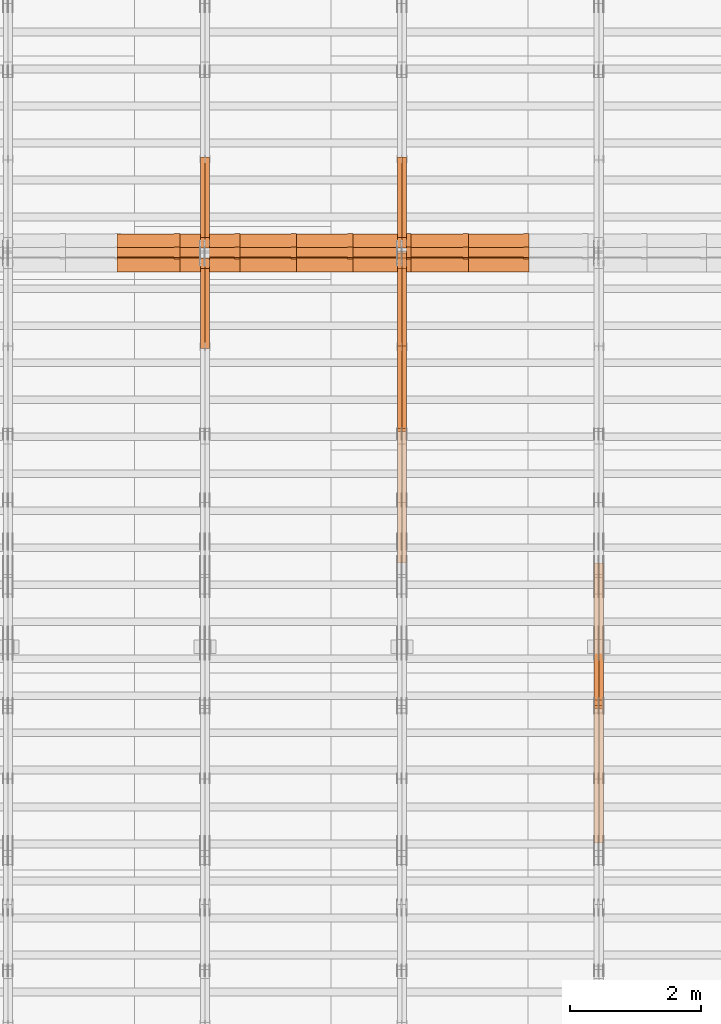
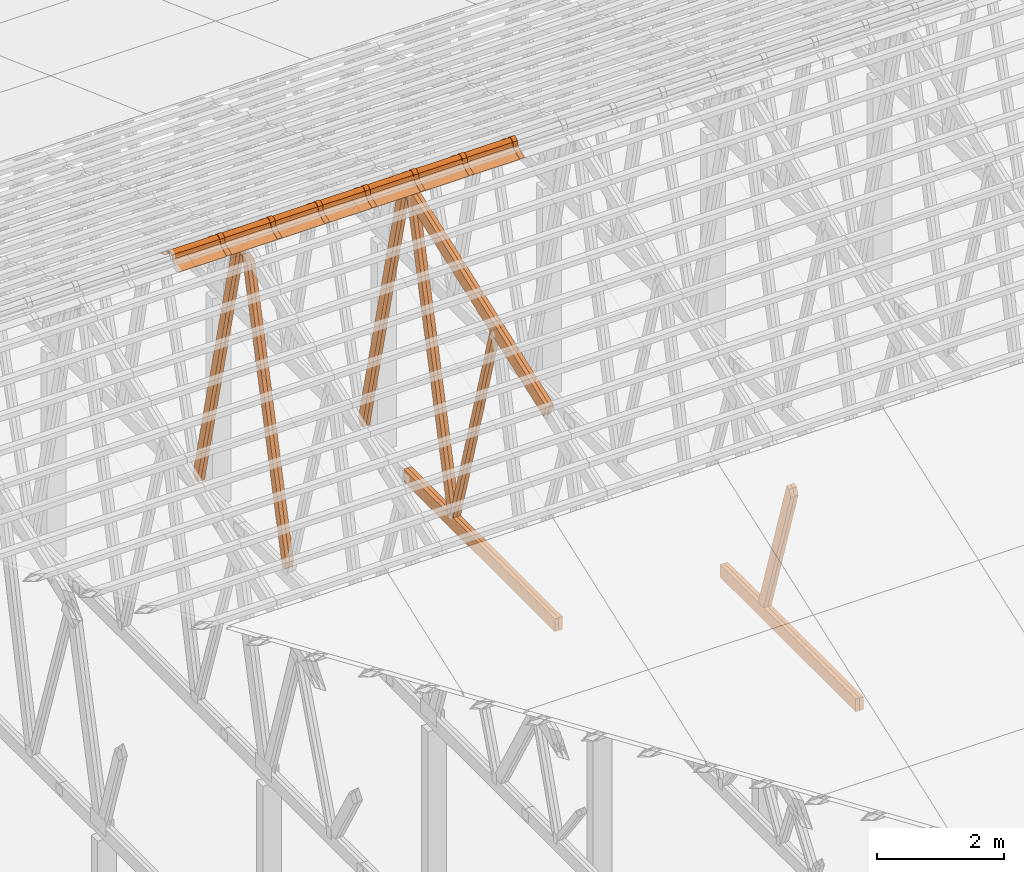
# One storey, part 27 of 189: 32 proxies.
"""IFC2X3 building model written with IfcOpenShell, lengths in millimetres."""

from ifc_helpers import new_model, entity, si_unit, converted_unit, derived_unit, direction, frame, frame_2d, origin, origin_2d_with_axis, place, context, subcontext, project, spatial, polyline, circle_curve, parameter, trimmed, segment, composite_curve, rectangle, outline, extrude, source, transform, mapped, material, type_object, type_shapes, element, save


model = new_model("IFC2X3")

# Units and contexts
model_context = context("Model", 3, precision=0.01, world=origin(), true_north=direction((6.12303176911189e-17, 1.0)))
body_context = subcontext(model_context, "Body", "Model", "MODEL_VIEW")
ifc_project = project(units=[si_unit("LENGTHUNIT", "METRE", prefix="MILLI"), si_unit("AREAUNIT", "SQUARE_METRE"), si_unit("VOLUMEUNIT", "CUBIC_METRE"), converted_unit("PLANEANGLEUNIT", "DEGREE", entity("IfcRatioMeasure", 0.0174532925199433), si_unit("PLANEANGLEUNIT", "RADIAN"), dimensions=[0, 0, 0, 0, 0, 0, 0]), si_unit("MASSUNIT", "GRAM", prefix="KILO"), derived_unit("MASSDENSITYUNIT", [(si_unit("MASSUNIT", "GRAM", prefix="KILO"), 1), (si_unit("LENGTHUNIT", "METRE"), -3)]), si_unit("TIMEUNIT", "SECOND"), si_unit("FREQUENCYUNIT", "HERTZ"), si_unit("THERMODYNAMICTEMPERATUREUNIT", "DEGREE_CELSIUS"), derived_unit("THERMALTRANSMITTANCEUNIT", [(si_unit("MASSUNIT", "GRAM", prefix="KILO"), 1), (si_unit("THERMODYNAMICTEMPERATUREUNIT", "KELVIN"), -1), (si_unit("TIMEUNIT", "SECOND"), -3)]), derived_unit("VOLUMETRICFLOWRATEUNIT", [(si_unit("LENGTHUNIT", "METRE"), 3), (si_unit("TIMEUNIT", "SECOND"), -1)]), si_unit("ELECTRICCURRENTUNIT", "AMPERE"), si_unit("ELECTRICVOLTAGEUNIT", "VOLT"), si_unit("POWERUNIT", "WATT"), si_unit("FORCEUNIT", "NEWTON"), si_unit("ILLUMINANCEUNIT", "LUX"), si_unit("LUMINOUSFLUXUNIT", "LUMEN"), si_unit("LUMINOUSINTENSITYUNIT", "CANDELA"), derived_unit("USERDEFINED", [(si_unit("MASSUNIT", "GRAM", prefix="KILO"), -1), (si_unit("LENGTHUNIT", "METRE"), -2), (si_unit("TIMEUNIT", "SECOND"), 3), (si_unit("LUMINOUSFLUXUNIT", "LUMEN"), 1)]), derived_unit("LINEARVELOCITYUNIT", [(si_unit("LENGTHUNIT", "METRE"), 1), (si_unit("TIMEUNIT", "SECOND"), -1)]), si_unit("PRESSUREUNIT", "PASCAL"), derived_unit("USERDEFINED", [(si_unit("LENGTHUNIT", "METRE"), -2), (si_unit("MASSUNIT", "GRAM", prefix="KILO"), 1), (si_unit("TIMEUNIT", "SECOND"), -2)])], contexts=[model_context])

# Site, building, storey
site_placement = place(None, origin())
site = spatial("IfcSite", under=ifc_project, at=site_placement, CompositionType="ELEMENT")
building_placement = place(site_placement, origin())
building = spatial("IfcBuilding", under=site, at=building_placement, CompositionType="ELEMENT")
storey_placement = place(building_placement, origin())
storey = spatial("IfcBuildingStorey", under=building, at=storey_placement, Name="Default", CompositionType="ELEMENT", Elevation=0.0)

# Proxies
ifc_material_1 = material(Name="IfcSurfaceStyle #130474")
building_element_proxy_type_1 = type_object("IfcBuildingElementProxyType", Name="T1-W4 130472", PredefinedType="NOTDEFINED", material=ifc_material_1)
shared_shape_1 = source(origin(), body_context, "Body", "SweptSolid", [
    extrude(outline(polyline([(-1688.09292256655, -85.0003489723785), (1071.44998120742, -85.0003489723785), (1178.19407811536, -0.00016040063201781), (1181.35435681367, 85.0004291726946), (-1742.9054935699, 85.0004291726946), (-1688.09292256655, -85.0003489723785)])), frame((1181.35446122976, 85.0007670757732, 0.0), z_axis=(0.0, 0.0, 1.0), x_axis=(-1.0, 0.0, 0.0)), (0.0, 0.0, 1.0), 69.9999999999998),
])
type_shapes(building_element_proxy_type_1, [shared_shape_1])
proxy_1_placement = place(building_placement, frame((24300.0, 7937.17021143291, 3028.170124945), z_axis=(-1.0, 0.0, 0.0), x_axis=(0.0, 0.306868406216492, -0.951751953644514)))
element("IfcBuildingElementProxy", 1, at=proxy_1_placement, inside=storey, type_object=building_element_proxy_type_1, material=ifc_material_1, Name="T1-W4", context=body_context, shape_type="MappedRepresentation", body=[
    mapped(shared_shape_1, transform((0.0, 0.0, 0.0), scale=1.0)),
])
ifc_material_2 = material(Name="IfcSurfaceStyle #130408")
building_element_proxy_type_2 = type_object("IfcBuildingElementProxyType", Name="T1-W4 130406", PredefinedType="NOTDEFINED", material=ifc_material_2)
shared_shape_2 = source(origin(), body_context, "Body", "SweptSolid", [
    extrude(outline(polyline([(-1688.09292256655, -85.0003489723785), (1071.44998120742, -85.0003489723785), (1178.19407811536, -0.00016040063201781), (1181.35435681367, 85.0004291726946), (-1742.9054935699, 85.0004291726946), (-1688.09292256655, -85.0003489723785)])), frame((1181.35446122976, 85.0007670757732, 0.0), z_axis=(0.0, 0.0, 1.0), x_axis=(-1.0, 0.0, 0.0)), (0.0, 0.0, 1.0), 69.9999999999998),
])
type_shapes(building_element_proxy_type_2, [shared_shape_2])
proxy_2_placement = place(building_placement, frame((24230.0, 7937.17021143291, 3028.170124945), z_axis=(-1.0, 0.0, 0.0), x_axis=(0.0, 0.306868406216492, -0.951751953644514)))
element("IfcBuildingElementProxy", 2, at=proxy_2_placement, inside=storey, type_object=building_element_proxy_type_2, material=ifc_material_2, Name="T1-W4", context=body_context, shape_type="MappedRepresentation", body=[
    mapped(shared_shape_2, transform((0.0, 0.0, 0.0), scale=1.0)),
])
ifc_material_3 = material(Name="IfcSurfaceStyle #127396")
building_element_proxy_type_3 = type_object("IfcBuildingElementProxyType", Name="T1-B6 127394", PredefinedType="NOTDEFINED", material=ifc_material_3)
shared_shape_3 = source(origin(), body_context, "Body", "SweptSolid", [
    extrude(rectangle(XDim=4266.763671875, YDim=245.000000000001, at=origin_2d_with_axis()), frame((2133.3818359375, 122.500000000001, 0.0), z_axis=(0.0, 0.0, 1.0), x_axis=(-1.0, 0.0, 0.0)), (0.0, 0.0, 1.0), 69.9999999999997),
])
type_shapes(building_element_proxy_type_3, [shared_shape_3])
proxy_3_placement = place(building_placement, frame((24300.0, 5762.466796875, 245.0), z_axis=(-1.0, 0.0, 0.0), x_axis=(0.0, 1.0, 0.0)))
element("IfcBuildingElementProxy", 3, at=proxy_3_placement, inside=storey, type_object=building_element_proxy_type_3, material=ifc_material_3, Name="T1-B6", context=body_context, shape_type="MappedRepresentation", body=[
    mapped(shared_shape_3, transform((0.0, 0.0, 0.0), scale=1.0)),
])
ifc_material_4 = material(Name="IfcSurfaceStyle #127339")
building_element_proxy_type_4 = type_object("IfcBuildingElementProxyType", Name="T1-B6 127337", PredefinedType="NOTDEFINED", material=ifc_material_4)
shared_shape_4 = source(origin(), body_context, "Body", "SweptSolid", [
    extrude(rectangle(XDim=4266.763671875, YDim=245.000000000001, at=origin_2d_with_axis()), frame((2133.3818359375, 122.500000000001, 0.0), z_axis=(0.0, 0.0, 1.0), x_axis=(-1.0, 0.0, 0.0)), (0.0, 0.0, 1.0), 69.9999999999997),
])
type_shapes(building_element_proxy_type_4, [shared_shape_4])
proxy_4_placement = place(building_placement, frame((24230.0, 5762.466796875, 245.0), z_axis=(-1.0, 0.0, 0.0), x_axis=(0.0, 1.0, 0.0)))
element("IfcBuildingElementProxy", 4, at=proxy_4_placement, inside=storey, type_object=building_element_proxy_type_4, material=ifc_material_4, Name="T1-B6", context=body_context, shape_type="MappedRepresentation", body=[
    mapped(shared_shape_4, transform((0.0, 0.0, 0.0), scale=1.0)),
])
ifc_material_5 = material(Name="IfcSurfaceStyle #116004")
building_element_proxy_type_5 = type_object("IfcBuildingElementProxyType", Name="T1-W5 116002", PredefinedType="NOTDEFINED", material=ifc_material_5)
shared_shape_5 = source(origin(), body_context, "Body", "SweptSolid", [
    extrude(outline(polyline([(-3233.61216530572, -72.4999091305202), (2153.79187521892, -72.4999091305202), (2171.36968478227, -7.18521572819375e-05), (2045.62106208646, 72.4999450565989), (-3137.17045678193, 72.4999450565989), (-3233.61216530572, -72.4999091305202)])), frame((2171.36968478227, 72.500192121173, 0.0), z_axis=(0.0, 0.0, 1.0), x_axis=(-1.0, 0.0, 0.0)), (0.0, 0.0, 1.0), 69.9999999999997),
])
type_shapes(building_element_proxy_type_5, [shared_shape_5])
proxy_5_placement = place(building_placement, frame((21300.0, 13261.0146935344, 262.082919891325), z_axis=(-1.0, 0.0, 0.0), x_axis=(0.0, 0.235625623344066, 0.97184389982328)))
element("IfcBuildingElementProxy", 5, at=proxy_5_placement, inside=storey, type_object=building_element_proxy_type_5, material=ifc_material_5, Name="T1-W5", context=body_context, shape_type="MappedRepresentation", body=[
    mapped(shared_shape_5, transform((0.0, 0.0, 0.0), scale=1.0)),
])
ifc_material_6 = material(Name="IfcSurfaceStyle #115938")
building_element_proxy_type_6 = type_object("IfcBuildingElementProxyType", Name="T1-W5 115936", PredefinedType="NOTDEFINED", material=ifc_material_6)
shared_shape_6 = source(origin(), body_context, "Body", "SweptSolid", [
    extrude(outline(polyline([(-3233.61216530572, -72.4999091305202), (2153.79187521892, -72.4999091305202), (2171.36968478227, -7.18521572819375e-05), (2045.62106208646, 72.4999450565989), (-3137.17045678193, 72.4999450565989), (-3233.61216530572, -72.4999091305202)])), frame((2171.36968478227, 72.500192121173, 0.0), z_axis=(0.0, 0.0, 1.0), x_axis=(-1.0, 0.0, 0.0)), (0.0, 0.0, 1.0), 69.9999999999997),
])
type_shapes(building_element_proxy_type_6, [shared_shape_6])
proxy_6_placement = place(building_placement, frame((21230.0, 13261.0146935344, 262.082919891325), z_axis=(-1.0, 0.0, 0.0), x_axis=(0.0, 0.235625623344066, 0.97184389982328)))
element("IfcBuildingElementProxy", 6, at=proxy_6_placement, inside=storey, type_object=building_element_proxy_type_6, material=ifc_material_6, Name="T1-W5", context=body_context, shape_type="MappedRepresentation", body=[
    mapped(shared_shape_6, transform((0.0, 0.0, 0.0), scale=1.0)),
])
ifc_material_7 = material(Name="IfcSurfaceStyle #115872")
building_element_proxy_type_7 = type_object("IfcBuildingElementProxyType", Name="T1-W5 115870", PredefinedType="NOTDEFINED", material=ifc_material_7)
shared_shape_7 = source(origin(), body_context, "Body", "SweptSolid", [
    extrude(outline(polyline([(-3137.17045678193, -72.5002081306407), (2045.62106208646, -72.5002081306408), (2171.36968478227, 5.58426931168476e-05), (2153.79187521892, 72.5001802092942), (-3233.61216530572, 72.5001802092942), (-3137.17045678193, -72.5002081306407)])), frame((2171.36968478227, 72.5001802092942, 0.0), z_axis=(0.0, 0.0, 1.0), x_axis=(-1.0, 0.0, 0.0)), (0.0, 0.0, 1.0), 69.9999999999997),
])
type_shapes(building_element_proxy_type_7, [shared_shape_7])
proxy_7_placement = place(building_placement, frame((21300.0, 16098.0675635854, 227.917113003597), z_axis=(-1.0, 0.0, 0.0), x_axis=(0.0, -0.235625623344066, 0.971843899823279)))
element("IfcBuildingElementProxy", 7, at=proxy_7_placement, inside=storey, type_object=building_element_proxy_type_7, material=ifc_material_7, Name="T1-W5", context=body_context, shape_type="MappedRepresentation", body=[
    mapped(shared_shape_7, transform((0.0, 0.0, 0.0), scale=1.0)),
])
ifc_material_8 = material(Name="IfcSurfaceStyle #115806")
building_element_proxy_type_8 = type_object("IfcBuildingElementProxyType", Name="T1-W5 115804", PredefinedType="NOTDEFINED", material=ifc_material_8)
shared_shape_8 = source(origin(), body_context, "Body", "SweptSolid", [
    extrude(outline(polyline([(-3137.17045678193, -72.5002081306407), (2045.62106208646, -72.5002081306408), (2171.36968478227, 5.58426931168476e-05), (2153.79187521892, 72.5001802092942), (-3233.61216530572, 72.5001802092942), (-3137.17045678193, -72.5002081306407)])), frame((2171.36968478227, 72.5001802092942, 0.0), z_axis=(0.0, 0.0, 1.0), x_axis=(-1.0, 0.0, 0.0)), (0.0, 0.0, 1.0), 69.9999999999997),
])
type_shapes(building_element_proxy_type_8, [shared_shape_8])
proxy_8_placement = place(building_placement, frame((21230.0, 16098.0675635854, 227.917113003597), z_axis=(-1.0, 0.0, 0.0), x_axis=(0.0, -0.235625623344066, 0.971843899823279)))
element("IfcBuildingElementProxy", 8, at=proxy_8_placement, inside=storey, type_object=building_element_proxy_type_8, material=ifc_material_8, Name="T1-W5", context=body_context, shape_type="MappedRepresentation", body=[
    mapped(shared_shape_8, transform((0.0, 0.0, 0.0), scale=1.0)),
])
ifc_material_9 = material(Name="IfcSurfaceStyle #115740")
building_element_proxy_type_9 = type_object("IfcBuildingElementProxyType", Name="T1-W6 115738", PredefinedType="NOTDEFINED", material=ifc_material_9)
shared_shape_9 = source(origin(), body_context, "Body", "SweptSolid", [
    extrude(outline(polyline([(-2640.84340836012, -47.4996765865792), (1711.12245024294, -47.4996765865792), (1797.68490303083, -9.57690019346202e-05), (1800.72595169379, 47.4997244710801), (-2668.68989660745, 47.4997244710801), (-2640.84340836012, -47.4996765865792)])), frame((1800.72595169379, 47.5003009358159, 0.0), z_axis=(0.0, 0.0, 1.0), x_axis=(-1.0, 0.0, 0.0)), (0.0, 0.0, 1.0), 69.9999999999997),
])
type_shapes(building_element_proxy_type_9, [shared_shape_9])
proxy_9_placement = place(building_placement, frame((21300.0, 12074.2896156894, 4533.9586582452), z_axis=(-1.0, 0.0, 0.0), x_axis=(0.0, 0.28128598310461, -0.959623986626467)))
element("IfcBuildingElementProxy", 9, at=proxy_9_placement, inside=storey, type_object=building_element_proxy_type_9, material=ifc_material_9, Name="T1-W6", context=body_context, shape_type="MappedRepresentation", body=[
    mapped(shared_shape_9, transform((0.0, 0.0, 0.0), scale=1.0)),
])
ifc_material_10 = material(Name="IfcSurfaceStyle #115674")
building_element_proxy_type_10 = type_object("IfcBuildingElementProxyType", Name="T1-W6 115672", PredefinedType="NOTDEFINED", material=ifc_material_10)
shared_shape_10 = source(origin(), body_context, "Body", "SweptSolid", [
    extrude(outline(polyline([(-2640.84340836012, -47.4996765865792), (1711.12245024294, -47.4996765865792), (1797.68490303083, -9.57690019346202e-05), (1800.72595169379, 47.4997244710801), (-2668.68989660745, 47.4997244710801), (-2640.84340836012, -47.4996765865792)])), frame((1800.72595169379, 47.5003009358159, 0.0), z_axis=(0.0, 0.0, 1.0), x_axis=(-1.0, 0.0, 0.0)), (0.0, 0.0, 1.0), 69.9999999999997),
])
type_shapes(building_element_proxy_type_10, [shared_shape_10])
proxy_10_placement = place(building_placement, frame((21230.0, 12074.2896156894, 4533.9586582452), z_axis=(-1.0, 0.0, 0.0), x_axis=(0.0, 0.28128598310461, -0.959623986626467)))
element("IfcBuildingElementProxy", 10, at=proxy_10_placement, inside=storey, type_object=building_element_proxy_type_10, material=ifc_material_10, Name="T1-W6", context=body_context, shape_type="MappedRepresentation", body=[
    mapped(shared_shape_10, transform((0.0, 0.0, 0.0), scale=1.0)),
])
ifc_material_11 = material(Name="IfcSurfaceStyle #111720")
building_element_proxy_type_11 = type_object("IfcBuildingElementProxyType", Name="T1-B3 111718", PredefinedType="NOTDEFINED", material=ifc_material_11)
shared_shape_11 = source(origin(), body_context, "Body", "SweptSolid", [
    extrude(rectangle(XDim=4751.0283203125, YDim=245.000000000001, at=origin_2d_with_axis()), frame((2375.51416015625, 122.5, 0.0), z_axis=(0.0, 0.0, 1.0), x_axis=(-1.0, 0.0, 0.0)), (0.0, 0.0, 1.0), 69.9999999999997),
])
type_shapes(building_element_proxy_type_11, [shared_shape_11])
proxy_11_placement = place(building_placement, frame((21300.0, 10029.23046875, 245.0), z_axis=(-1.0, 0.0, 0.0), x_axis=(0.0, 1.0, 0.0)))
element("IfcBuildingElementProxy", 11, at=proxy_11_placement, inside=storey, type_object=building_element_proxy_type_11, material=ifc_material_11, Name="T1-B3", context=body_context, shape_type="MappedRepresentation", body=[
    mapped(shared_shape_11, transform((0.0, 0.0, 0.0), scale=1.0)),
])
ifc_material_12 = material(Name="IfcSurfaceStyle #111663")
building_element_proxy_type_12 = type_object("IfcBuildingElementProxyType", Name="T1-B3 111661", PredefinedType="NOTDEFINED", material=ifc_material_12)
shared_shape_12 = source(origin(), body_context, "Body", "SweptSolid", [
    extrude(rectangle(XDim=4751.0283203125, YDim=245.000000000001, at=origin_2d_with_axis()), frame((2375.51416015625, 122.5, 0.0), z_axis=(0.0, 0.0, 1.0), x_axis=(-1.0, 0.0, 0.0)), (0.0, 0.0, 1.0), 69.9999999999997),
])
type_shapes(building_element_proxy_type_12, [shared_shape_12])
proxy_12_placement = place(building_placement, frame((21230.0, 10029.23046875, 245.0), z_axis=(-1.0, 0.0, 0.0), x_axis=(0.0, 1.0, 0.0)))
element("IfcBuildingElementProxy", 12, at=proxy_12_placement, inside=storey, type_object=building_element_proxy_type_12, material=ifc_material_12, Name="T1-B3", context=body_context, shape_type="MappedRepresentation", body=[
    mapped(shared_shape_12, transform((0.0, 0.0, 0.0), scale=1.0)),
])
ifc_material_13 = material(Name="IfcSurfaceStyle #111132")
building_element_proxy_type_13 = type_object("IfcBuildingElementProxyType", Name="T1-T3 111130", PredefinedType="NOTDEFINED", material=ifc_material_13)
shared_shape_13 = source(origin(), body_context, "Body", "SweptSolid", [
    extrude(outline(polyline([(-2341.64890001385, -122.499972785692), (2386.23525922045, -122.499972785692), (2297.06252495753, 122.499972785692), (-2341.64888416412, 122.499972785692), (-2341.64890001385, -122.499972785692)])), frame((2386.23525922045, 122.499973888764, 0.0), z_axis=(0.0, 0.0, 1.0), x_axis=(-1.0, 0.0, 0.0)), (0.0, 0.0, 1.0), 69.9999999999997),
])
type_shapes(building_element_proxy_type_13, [shared_shape_13])
proxy_13_placement = place(building_placement, frame((21300.0, 14833.7949607394, 5538.33627266055), z_axis=(-1.0, 0.0, 0.0), x_axis=(0.0, -0.939692620785908, -0.342020143325669)))
element("IfcBuildingElementProxy", 13, at=proxy_13_placement, inside=storey, type_object=building_element_proxy_type_13, material=ifc_material_13, Name="T1-T3", context=body_context, shape_type="MappedRepresentation", body=[
    mapped(shared_shape_13, transform((0.0, 0.0, 0.0), scale=1.0)),
])
ifc_material_14 = material(Name="IfcSurfaceStyle #111075")
building_element_proxy_type_14 = type_object("IfcBuildingElementProxyType", Name="T1-T3 111073", PredefinedType="NOTDEFINED", material=ifc_material_14)
shared_shape_14 = source(origin(), body_context, "Body", "SweptSolid", [
    extrude(outline(polyline([(-2341.64890001385, -122.499972785692), (2386.23525922045, -122.499972785692), (2297.06252495753, 122.499972785692), (-2341.64888416412, 122.499972785692), (-2341.64890001385, -122.499972785692)])), frame((2386.23525922045, 122.499973888764, 0.0), z_axis=(0.0, 0.0, 1.0), x_axis=(-1.0, 0.0, 0.0)), (0.0, 0.0, 1.0), 69.9999999999997),
])
type_shapes(building_element_proxy_type_14, [shared_shape_14])
proxy_14_placement = place(building_placement, frame((21230.0, 14833.7949607394, 5538.33627266055), z_axis=(-1.0, 0.0, 0.0), x_axis=(0.0, -0.939692620785908, -0.342020143325669)))
element("IfcBuildingElementProxy", 14, at=proxy_14_placement, inside=storey, type_object=building_element_proxy_type_14, material=ifc_material_14, Name="T1-T3", context=body_context, shape_type="MappedRepresentation", body=[
    mapped(shared_shape_14, transform((0.0, 0.0, 0.0), scale=1.0)),
])
ifc_material_15 = material(Name="IfcSurfaceStyle #100214")
building_element_proxy_type_15 = type_object("IfcBuildingElementProxyType", Name="T1-W5 100212", PredefinedType="NOTDEFINED", material=ifc_material_15)
shared_shape_15 = source(origin(), body_context, "Body", "SweptSolid", [
    extrude(outline(polyline([(-3233.61216530572, -72.4999091305202), (2153.79187521892, -72.4999091305202), (2171.36968478227, -7.18521572819375e-05), (2045.62106208646, 72.4999450565989), (-3137.17045678193, 72.4999450565989), (-3233.61216530572, -72.4999091305202)])), frame((2171.36968478227, 72.500192121173, 0.0), z_axis=(0.0, 0.0, 1.0), x_axis=(-1.0, 0.0, 0.0)), (0.0, 0.0, 1.0), 69.9999999999997),
])
type_shapes(building_element_proxy_type_15, [shared_shape_15])
proxy_15_placement = place(building_placement, frame((18300.0, 13261.0146935344, 262.082919891325), z_axis=(-1.0, 0.0, 0.0), x_axis=(0.0, 0.235625623344066, 0.97184389982328)))
element("IfcBuildingElementProxy", 15, at=proxy_15_placement, inside=storey, type_object=building_element_proxy_type_15, material=ifc_material_15, Name="T1-W5", context=body_context, shape_type="MappedRepresentation", body=[
    mapped(shared_shape_15, transform((0.0, 0.0, 0.0), scale=1.0)),
])
ifc_material_16 = material(Name="IfcSurfaceStyle #100148")
building_element_proxy_type_16 = type_object("IfcBuildingElementProxyType", Name="T1-W5 100146", PredefinedType="NOTDEFINED", material=ifc_material_16)
shared_shape_16 = source(origin(), body_context, "Body", "SweptSolid", [
    extrude(outline(polyline([(-3233.61216530572, -72.4999091305202), (2153.79187521892, -72.4999091305202), (2171.36968478227, -7.18521572819375e-05), (2045.62106208646, 72.4999450565989), (-3137.17045678193, 72.4999450565989), (-3233.61216530572, -72.4999091305202)])), frame((2171.36968478227, 72.500192121173, 0.0), z_axis=(0.0, 0.0, 1.0), x_axis=(-1.0, 0.0, 0.0)), (0.0, 0.0, 1.0), 69.9999999999997),
])
type_shapes(building_element_proxy_type_16, [shared_shape_16])
proxy_16_placement = place(building_placement, frame((18230.0, 13261.0146935344, 262.082919891325), z_axis=(-1.0, 0.0, 0.0), x_axis=(0.0, 0.235625623344066, 0.97184389982328)))
element("IfcBuildingElementProxy", 16, at=proxy_16_placement, inside=storey, type_object=building_element_proxy_type_16, material=ifc_material_16, Name="T1-W5", context=body_context, shape_type="MappedRepresentation", body=[
    mapped(shared_shape_16, transform((0.0, 0.0, 0.0), scale=1.0)),
])
ifc_material_17 = material(Name="IfcSurfaceStyle #100082")
building_element_proxy_type_17 = type_object("IfcBuildingElementProxyType", Name="T1-W5 100080", PredefinedType="NOTDEFINED", material=ifc_material_17)
shared_shape_17 = source(origin(), body_context, "Body", "SweptSolid", [
    extrude(outline(polyline([(-3137.17045678193, -72.5002081306407), (2045.62106208646, -72.5002081306408), (2171.36968478227, 5.58426931168476e-05), (2153.79187521892, 72.5001802092942), (-3233.61216530572, 72.5001802092942), (-3137.17045678193, -72.5002081306407)])), frame((2171.36968478227, 72.5001802092942, 0.0), z_axis=(0.0, 0.0, 1.0), x_axis=(-1.0, 0.0, 0.0)), (0.0, 0.0, 1.0), 69.9999999999997),
])
type_shapes(building_element_proxy_type_17, [shared_shape_17])
proxy_17_placement = place(building_placement, frame((18300.0, 16098.0675635854, 227.917113003597), z_axis=(-1.0, 0.0, 0.0), x_axis=(0.0, -0.235625623344066, 0.971843899823279)))
element("IfcBuildingElementProxy", 17, at=proxy_17_placement, inside=storey, type_object=building_element_proxy_type_17, material=ifc_material_17, Name="T1-W5", context=body_context, shape_type="MappedRepresentation", body=[
    mapped(shared_shape_17, transform((0.0, 0.0, 0.0), scale=1.0)),
])
ifc_material_18 = material(Name="IfcSurfaceStyle #100016")
building_element_proxy_type_18 = type_object("IfcBuildingElementProxyType", Name="T1-W5 100014", PredefinedType="NOTDEFINED", material=ifc_material_18)
shared_shape_18 = source(origin(), body_context, "Body", "SweptSolid", [
    extrude(outline(polyline([(-3137.17045678193, -72.5002081306407), (2045.62106208646, -72.5002081306408), (2171.36968478227, 5.58426931168476e-05), (2153.79187521892, 72.5001802092942), (-3233.61216530572, 72.5001802092942), (-3137.17045678193, -72.5002081306407)])), frame((2171.36968478227, 72.5001802092942, 0.0), z_axis=(0.0, 0.0, 1.0), x_axis=(-1.0, 0.0, 0.0)), (0.0, 0.0, 1.0), 69.9999999999997),
])
type_shapes(building_element_proxy_type_18, [shared_shape_18])
proxy_18_placement = place(building_placement, frame((18230.0, 16098.0675635854, 227.917113003597), z_axis=(-1.0, 0.0, 0.0), x_axis=(0.0, -0.235625623344066, 0.971843899823279)))
element("IfcBuildingElementProxy", 18, at=proxy_18_placement, inside=storey, type_object=building_element_proxy_type_18, material=ifc_material_18, Name="T1-W5", context=body_context, shape_type="MappedRepresentation", body=[
    mapped(shared_shape_18, transform((0.0, 0.0, 0.0), scale=1.0)),
])
ifc_material_19 = material()
building_element_proxy_type_19 = type_object("IfcBuildingElementProxyType", Name="P75", PredefinedType="NOTDEFINED", material=ifc_material_19)
shared_shape_19 = source(origin(), body_context, "Body", "SweptSolid", [
    extrude(outline(composite_curve([segment(polyline([(-69.4623915065845, -4.60763114971976), (47.4521071665907, -4.60763114971981)]), True, "CONTINUOUS"), segment(trimmed(circle_curve(frame_2d((119.940978060963, 14.6372018310859), x_axis=(-0.966518278591622, -0.256597773077395)), 75.0), [parameter(6.61555373744412e-13)], [parameter(180.0)], True, "PARAMETER"), True, "CONTINUOUS"), segment(polyline([(192.429848955335, 33.882034811891), (182.764666169419, 31.3160570811166)]), True, "CONTINUOUS"), segment(trimmed(circle_curve(frame_2d((119.940978060963, 14.6372018310859), x_axis=(-0.966518278591622, -0.256597773077395)), 65.0), [parameter(1.06866637297174e-12)], [parameter(180.0)], True, "PARAMETER"), False, "CONTINUOUS"), segment(polyline([(57.1172899525073, -2.04165341894578), (47.4521071665911, 5.39236885028051)]), True, "CONTINUOUS"), segment(polyline([(47.4521071665911, 5.39236885028052), (-70.7672243976422, 5.39236885028094)]), True, "CONTINUOUS"), segment(polyline([(-70.7672243976422, 5.39236885028094), (-194.776190618495, -27.5303655446341)]), True, "CONTINUOUS"), segment(polyline([(-194.776190618495, -27.5303655446341), (-192.210212887721, -37.1955483305503)]), True, "CONTINUOUS"), segment(polyline([(-192.210212887721, -37.1955483305503), (-69.4623915065845, -4.60763114971974)]), True, "CONTINUOUS")], self_intersect=False)), frame((0.0, 106.775760402721, -56.5599052870917), z_axis=(1.0, 0.0, 0.0), x_axis=(0.0, -0.820468487122275, 0.571691754041709)), (0.0, 0.0, 1.0), 867.000000000001),
    extrude(outline(composite_curve([segment(polyline([(62.2906866429439, -18.428943356533), (189.290686642944, -18.428943356533)]), True, "CONTINUOUS"), segment(polyline([(189.290686642944, -18.428943356533), (189.290686642944, -8.42894335653292)]), True, "CONTINUOUS"), segment(polyline([(189.290686642944, -8.42894335653292), (62.2906866429439, -8.42894335653294)]), True, "CONTINUOUS"), segment(polyline([(62.2906866429439, -8.42894335653294), (-41.0348065006093, 19.0026034957362)]), True, "CONTINUOUS"), segment(trimmed(circle_curve(frame_2d((-125.709313357056, 11.5710566434651), x_axis=(1.0, 0.0)), 85.0), [parameter(5.01577186738723)], [parameter(180.0)], True, "PARAMETER"), True, "CONTINUOUS"), segment(polyline([(-210.709313357056, 11.5710566434656), (-200.709313357056, 11.5710566434656)]), True, "CONTINUOUS"), segment(trimmed(circle_curve(frame_2d((-125.709313357056, 11.5710566434651), x_axis=(1.0, 0.0)), 75.0), [parameter(3.05333249420498e-13)], [parameter(180.0)], True, "PARAMETER"), False, "CONTINUOUS"), segment(polyline([(-50.7093133570542, 11.5710566434655), (62.290686642944, -18.4289433565322)]), True, "CONTINUOUS")], self_intersect=False)), frame((867.0, 114.170579674061, -53.8683539143053), z_axis=(1.0, 0.0, 0.0), x_axis=(0.0, 0.939692620785914, -0.342020143325653)), (0.0, 0.0, 1.0), 86.9999999999998),
])
type_shapes(building_element_proxy_type_19, [shared_shape_19])
for number, where, name in (
    (19, (22212.9353253273, 14755.0000438631, 5865.69618295448), "P75, generic model20:P75"),
    (20, (21292.9353253273, 14755.0000438631, 5865.69618295448), "P75, generic model20:P75"),
    (21, (20412.9353253273, 14755.0000438631, 5865.69618295448), "P75, generic model20:P75"),
    (22, (19532.9353253273, 14755.0000438631, 5865.69618295448), "P75, generic model20:P75"),
    (23, (18672.9353253273, 14755.0000438631, 5865.69618295448), "P75, generic model20:P75"),
    (24, (17812.9353253273, 14755.0000438631, 5865.69618295448), "P75, generic model20:P75"),
    (25, (16892.9353253273, 14755.0000438631, 5865.69618295448), "P75, generic model20:P75"),
):
    element("IfcBuildingElementProxy", number, at=place(storey_placement, frame(where)), inside=storey, type_object=building_element_proxy_type_19, material=ifc_material_19, Name=name, ObjectType="P75, generic model20:P75", context=body_context, shape_type="MappedRepresentation", body=[
        mapped(shared_shape_19, transform((0.0, 0.0, 0.0), scale=1.0)),
    ])
building_element_proxy_type_20 = type_object("IfcBuildingElementProxyType", Name="P75", PredefinedType="NOTDEFINED", material=ifc_material_19)
shared_shape_20 = source(origin(), body_context, "Body", "SweptSolid", [
    extrude(outline(composite_curve([segment(polyline([(68.3189789579817, 13.3705352460084), (195.318978957982, 13.3705352460084)]), True, "CONTINUOUS"), segment(polyline([(195.318978957982, 13.3705352460084), (195.318978957982, 23.3705352460084)]), True, "CONTINUOUS"), segment(polyline([(195.318978957982, 23.3705352460084), (67.014146066922, 23.3705352460088)]), True, "CONTINUOUS"), segment(polyline([(67.014146066922, 23.3705352460088), (-47.2469987727929, -6.96428196807339)]), True, "CONTINUOUS"), segment(polyline([(-47.2469987727929, -6.96428196807339), (-54.6810210420187, -16.62946475399)]), True, "CONTINUOUS"), segment(trimmed(circle_curve(frame_2d((-119.681021042019, -16.6294647539896), x_axis=(1.0, 0.0)), 65.0), [parameter(180.0)], [parameter(359.999999999999)], True, "PARAMETER"), False, "CONTINUOUS"), segment(polyline([(-184.681021042019, -16.6294647539905), (-194.681021042019, -16.6294647539901)]), True, "CONTINUOUS"), segment(trimmed(circle_curve(frame_2d((-119.681021042019, -16.6294647539896), x_axis=(1.0, 0.0)), 75.0), [parameter(180.0)], [parameter(359.999999999999)], True, "PARAMETER"), True, "CONTINUOUS"), segment(polyline([(-44.6810210420183, -16.6294647539898), (68.3189789579816, 13.3705352460083)]), True, "CONTINUOUS")], self_intersect=False)), frame((0.0, -106.775760402721, -56.5599052870916), z_axis=(1.0, 0.0, 0.0), x_axis=(0.0, -0.939692620785914, -0.342020143325654)), (0.0, 0.0, 1.0), 867.000000000001),
    extrude(outline(composite_curve([segment(polyline([(-64.9339130518847, 1.82825913317695), (-187.681734433021, -30.7596580476538)]), True, "CONTINUOUS"), segment(polyline([(-187.681734433021, -30.7596580476538), (-185.115756702247, -40.4248408335702)]), True, "CONTINUOUS"), segment(polyline([(-185.115756702247, -40.4248408335702), (-62.3679353211107, -7.83692365273935)]), True, "CONTINUOUS"), segment(polyline([(-62.3679353211107, -7.83692365273935), (44.5369162809878, -7.83692365273935)]), True, "CONTINUOUS"), segment(trimmed(circle_curve(frame_2d((124.469456515662, 21.0730921139827), x_axis=(-0.966518278591636, -0.256597773077402)), 85.0), [parameter(5.01577186738723)], [parameter(180.0)], True, "PARAMETER"), True, "CONTINUOUS"), segment(polyline([(206.623510195951, 42.8839028255618), (196.958327410034, 40.3179250947878)]), True, "CONTINUOUS"), segment(trimmed(circle_curve(frame_2d((124.469456515662, 21.0730921139827), x_axis=(-0.966518278591636, -0.256597773077402)), 75.0), [parameter(3.05333249420498e-13)], [parameter(180.0)], True, "PARAMETER"), False, "CONTINUOUS"), segment(polyline([(51.9805856212887, 1.82825913317622), (-64.9339130518846, 1.82825913317621)]), True, "CONTINUOUS")], self_intersect=False)), frame((867.0, -114.170579674061, -53.868353914305), z_axis=(-1.0, 0.0, 0.0), x_axis=(0.0, 0.820468487122275, 0.571691754041709)), (0.0, 0.0, -1.0), 86.9999999999998),
])
type_shapes(building_element_proxy_type_20, [shared_shape_20])
for number, where, name in (
    (26, (22212.9353253273, 14745.0000384614, 5850.69618295448), "P75, generic model20:P75"),
    (27, (21292.9353253273, 14745.0000384614, 5850.69618295448), "P75, generic model20:P75"),
    (28, (20412.9353253273, 14745.0000384614, 5850.69618295448), "P75, generic model20:P75"),
    (29, (19532.9353253273, 14745.0000384614, 5850.69618295448), "P75, generic model20:P75"),
    (30, (18672.9353253273, 14745.0000384614, 5850.69618295448), "P75, generic model20:P75"),
    (31, (17812.9353253273, 14745.0000384614, 5850.69618295448), "P75, generic model20:P75"),
    (32, (16892.9353253273, 14745.0000384614, 5850.69618295448), "P75, generic model20:P75"),
):
    element("IfcBuildingElementProxy", number, at=place(storey_placement, frame(where)), inside=storey, type_object=building_element_proxy_type_20, material=ifc_material_19, Name=name, ObjectType="P75, generic model20:P75", context=body_context, shape_type="MappedRepresentation", body=[
        mapped(shared_shape_20, transform((0.0, 0.0, 0.0), scale=1.0)),
    ])

save(model, "model.ifc")
